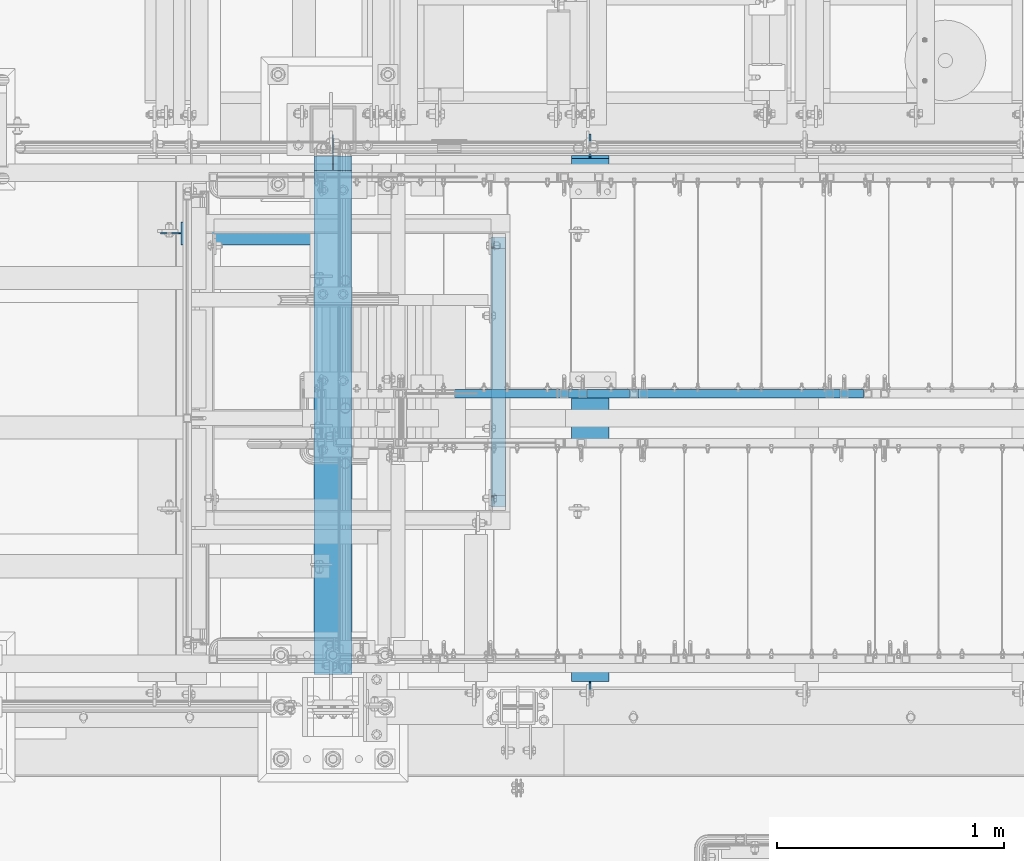
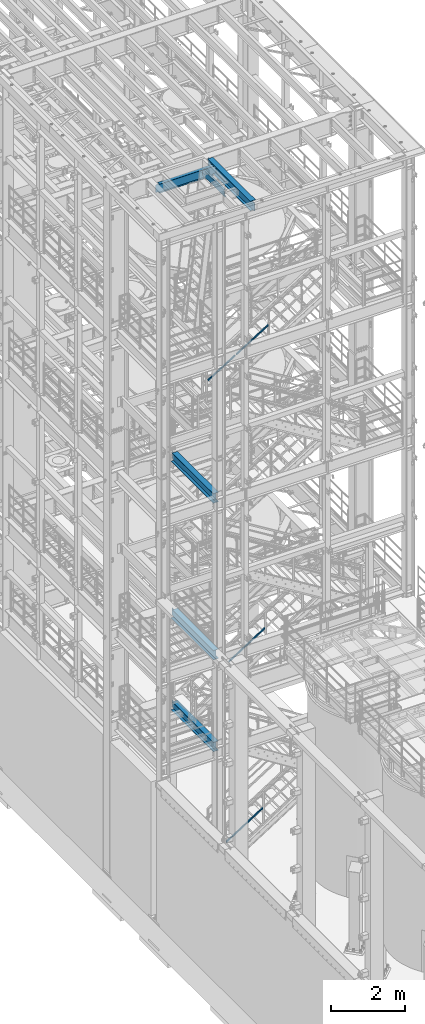
# One storey, part 966 of 1876: 6 beams, 4 members, 9 elements without a shape of their own.
"""IFC2X3 building model written with IfcOpenShell, lengths in millimetres."""

from ifc_helpers import new_model, si_unit, frame, origin_with_axes, place, context, subcontext, project, spatial, faceted_brep, material, type_object, element, aggregate, save


model = new_model("IFC2X3")

# Units and contexts
model_context = context("Model", 3, precision=1e-05, world=origin_with_axes())
body_context = subcontext(model_context, "Body", "Model", "MODEL_VIEW")
ifc_project = project(units=[si_unit("LENGTHUNIT", "METRE", prefix="MILLI"), si_unit("AREAUNIT", "SQUARE_METRE"), si_unit("VOLUMEUNIT", "CUBIC_METRE"), si_unit("MASSUNIT", "GRAM", prefix="KILO"), si_unit("TIMEUNIT", "SECOND"), si_unit("PLANEANGLEUNIT", "RADIAN"), si_unit("SOLIDANGLEUNIT", "STERADIAN"), si_unit("THERMODYNAMICTEMPERATUREUNIT", "DEGREE_CELSIUS"), si_unit("LUMINOUSINTENSITYUNIT", "LUMEN")], contexts=[model_context])

# Site, building, storey
site_placement = place(None, origin_with_axes())
site = spatial("IfcSite", under=ifc_project, at=site_placement, CompositionType="ELEMENT")
building_placement = place(site_placement, origin_with_axes())
building = spatial("IfcBuilding", under=site, at=building_placement, Name="Undefined", CompositionType="ELEMENT")
storey_placement = place(building_placement, origin_with_axes())
storey = spatial("IfcBuildingStorey", under=building, at=storey_placement, Name="Undefined", CompositionType="ELEMENT", Elevation=0.0)

# Assembly, beam
assembly_1_placement = place(storey_placement, origin_with_axes())
assembly_1 = element("IfcElementAssembly", 1, at=assembly_1_placement, inside=storey, Name="BEAM", AssemblyPlace="NOTDEFINED", PredefinedType="RIGID_FRAME")
ifc_material_1 = material(Name="STEEL/A992")
beam_type_1 = type_object("IfcBeamType", Name="W12X16", PredefinedType="NOTDEFINED")
beam_1_placement = place(assembly_1_placement, frame((949.325, -5029.2, 22402.8), z_axis=(0.0, 0.0, 1.0), x_axis=(1.0, 0.0, 0.0)))
beam_1 = element("IfcBeam", 2, at=beam_1_placement, type_object=beam_type_1, material=ifc_material_1, Name="BEAM", ObjectType="W12X16", context=body_context, shape_type="Brep", body=[
    faceted_brep([(1802.60625, -3.17500000000018, -146.049999999999), (1802.60625, -50.8000000000002, -146.049999999999), (1802.60625, -50.8000000000002, -152.400000000001), (1802.60625, 50.8000000000002, -152.400000000001), (1802.60625, 50.8000000000002, -146.049999999999), (1802.60625, 3.17500000000018, -146.049999999999), (1802.60625, 3.17500000000018, -139.699999809265), (1802.60625, -3.17500000000018, -139.699999809265), (1803.57297992259, 3.17500000000018, -134.839920291219), (1803.57297992259, -3.17500000000018, -134.839920291219), (1806.32599382307, 3.17500000000018, -130.719743823065), (1806.32599382307, -3.17500000000018, -130.719743823065), (1810.44617029122, 3.17500000000018, -127.966729922588), (1810.44617029122, -3.17500000000018, -127.966729922588), (1815.30624980927, 3.17500000000018, -127.0), (1815.30624980927, -3.17500000000018, -127.0), (1891.50625, -3.17500000000018, -127.0), (1891.50625, 3.17500000000018, -127.0), (1802.60625, 50.8000000000002, 146.049999999999), (1802.60625, 3.17500000000018, 146.049999999999), (108.74375, 3.17500000000018, 146.049999999999), (108.74375, 50.8000000000002, 146.049999999999), (108.74375, -3.17499999999995, -139.699999809261), (108.74375, 3.17500002570978, -139.699999809261), (108.74375, 3.17500009516311, -146.049999999999), (108.74375, 50.8, -146.049999999999), (108.74375, 50.8, -152.400000000001), (108.74375, -50.8, -152.400000000001), (108.74375, -50.8, -146.049999999999), (108.74375, -3.17499999999995, -146.049999999999), (107.777020077412, -3.17499999999995, -134.839920291215), (107.777020077412, 3.17500002492102, -134.839920291215), (105.024006176934, -3.17499999999995, -130.719743823061), (105.024006176934, 3.17500002425209, -130.719743823061), (100.90382970878, -3.17499999999995, -127.966729922584), (100.90382970878, 3.17500002380461, -127.966729922584), (96.0437501907345, -3.17499999999995, -126.999999999996), (96.0437501907345, 3.17500002364682, -126.999999999996), (19.84375, -3.17499999999995, -126.999999999996), (19.84375, 3.17499999999995, -126.999999999996), (19.8437500000002, -3.17500000000018, 127.0), (19.8437500000002, 3.17500000000018, 127.0), (96.043750190735, -3.17500000000018, 127.0), (96.043750190735, 3.17500000000018, 127.0), (100.90382970878, -3.17500000000018, 127.966729922588), (100.90382970878, 3.17500000000018, 127.966729922588), (105.024006176934, -3.17500000000018, 130.719743823065), (105.024006176934, 3.17500000000018, 130.719743823065), (107.777020077412, -3.17500000000018, 134.839920291219), (107.777020077412, 3.17500000000018, 134.839920291219), (108.74375, -3.17500000000018, 139.699999809265), (108.74375, 3.17500000000018, 139.699999809265), (108.74375, -50.8000000000002, 152.400000000001), (108.74375, 50.8000000000002, 152.400000000001), (108.74375, -3.17500000000018, 146.049999999999), (108.74375, -50.8000000000002, 146.049999999999), (1802.60625, -3.17500000000018, 146.049999999999), (1802.60625, -50.8000000000002, 146.049999999999), (1802.60625, -50.8000000000002, 152.400000000001), (1802.60625, 50.8000000000002, 152.400000000001), (1802.60625, -3.17500000000018, 139.699999809265), (1802.60625, 3.17500000000018, 139.699999809265), (1803.57297992259, -3.17500000000018, 134.839920291219), (1803.57297992259, 3.17500000000018, 134.839920291219), (1806.32599382307, -3.17500000000018, 130.719743823065), (1806.32599382307, 3.17500000000018, 130.719743823065), (1810.44617029122, -3.17500000000018, 127.966729922588), (1810.44617029122, 3.17500000000018, 127.966729922588), (1815.30624980927, -3.17500000000018, 127.0), (1815.30624980927, 3.17500000000018, 127.0), (1891.50625, -3.17500000000018, 127.0), (1891.50625, 3.17500000000018, 127.0)], [[[0, 1, 2, 3, 4, 5, 6, 7]], [[7, 6, 8, 9]], [[9, 8, 10, 11]], [[11, 10, 12, 13]], [[13, 12, 14, 15]], [[16, 15, 14, 17]], [[18, 19, 20, 21]], [[22, 23, 24, 25, 26, 27, 28, 29]], [[30, 31, 23, 22]], [[32, 33, 31, 30]], [[34, 35, 33, 32]], [[36, 37, 35, 34]], [[38, 39, 37, 36]], [[40, 41, 39, 38]], [[42, 43, 41, 40]], [[44, 45, 43, 42]], [[46, 47, 45, 44]], [[48, 49, 47, 46]], [[50, 51, 49, 48]], [[52, 53, 21, 20, 51, 50, 54, 55]], [[56, 57, 55, 54]], [[57, 58, 52, 55]], [[58, 59, 53, 52]], [[59, 18, 21, 53]], [[58, 57, 56, 60, 61, 19, 18, 59]], [[62, 63, 61, 60]], [[64, 65, 63, 62]], [[66, 67, 65, 64]], [[68, 69, 67, 66]], [[70, 71, 69, 68]], [[71, 70, 16, 17]], [[33, 35, 37, 39, 41, 43, 45, 47, 49, 51, 20, 19, 61, 63, 65, 67, 69, 71, 17, 14, 12, 10, 8, 6, 5, 24, 23, 31]], [[5, 4, 25, 24]], [[4, 3, 26, 25]], [[3, 2, 27, 26]], [[2, 1, 28, 27]], [[1, 0, 29, 28]], [[0, 7, 9, 11, 13, 15, 16, 70, 68, 66, 64, 62, 60, 56, 54, 50, 48, 46, 44, 42, 40, 38, 36, 34, 32, 30, 22, 29]]]),
])
aggregate(assembly_1, [beam_1])

# Assembly, member
assembly_2_placement = place(storey_placement, origin_with_axes())
assembly_2 = element("IfcElementAssembly", 3, at=assembly_2_placement, inside=storey, Name="RAIL", AssemblyPlace="NOTDEFINED", PredefinedType="RIGID_FRAME")
ifc_material_2 = material()
member_type = type_object("IfcMemberType", Name="HSS1-1/2X1-1/2X1/8", PredefinedType="NOTDEFINED")
member_1_placement = place(assembly_2_placement, frame((2743.20000001392, -5734.05000114554, 710.652585995032), z_axis=(-0.53569741975471, 0.0, 0.844410015613355), x_axis=(0.844410015326383, 0.0, 0.535697420207059)))
member_1 = element("IfcMember", 4, at=member_1_placement, type_object=member_type, material=ifc_material_2, Name="RAIL", ObjectType="HSS1-1/2X1-1/2X1/8", context=body_context, shape_type="Brep", body=[
    faceted_brep([(1373.21326696754, -19.0499992349996, 19.0499992350346), (1349.04246072927, -19.0499992349996, -19.049999234971), (1349.04246072927, 19.0499992349996, -19.049999234971), (1373.21326696754, 19.0499992349996, 19.0499992350346), (1371.19903306392, -15.8749992829999, 15.8749992830342), (1371.19903306392, 15.8749992829999, 15.8749992830342), (1351.0566946329, 15.8749992829999, -15.8749992829707), (1351.0566946329, -15.8749992829999, -15.8749992829707), (34.6455325374254, 19.0499992349996, 19.049999235012), (34.6455325374254, -19.0499992349996, 19.049999235012), (10.4747262991696, -19.0499992349996, -19.0499992349991), (10.4747262991696, 19.0499992349996, -19.0499992349991), (32.6312986338025, 15.8749992829999, 15.8749992830109), (32.6312986338025, -15.8749992829999, 15.8749992830109), (12.4889602027924, -15.8749992829999, -15.8749992829981), (12.4889602027924, 15.8749992829999, -15.8749992829981)], [[[0, 1, 2, 3], [4, 5, 6, 7]], [[0, 3, 8, 9]], [[2, 1, 10, 11]], [[1, 0, 9, 10]], [[3, 2, 11, 8]], [[10, 9, 8, 11], [12, 13, 14, 15]], [[4, 7, 14, 13]], [[7, 6, 15, 14]], [[6, 5, 12, 15]], [[5, 4, 13, 12]]]),
])
aggregate(assembly_2, [member_1])

assembly_3_placement = place(storey_placement, origin_with_axes())
assembly_3 = element("IfcElementAssembly", 5, at=assembly_3_placement, inside=storey, Name="RAIL", AssemblyPlace="NOTDEFINED", PredefinedType="RIGID_FRAME")
member_2_placement = place(assembly_3_placement, frame((2825.74999894891, -5734.05000114554, 6615.25681662695), z_axis=(-0.536875491934336, 0.0, 0.843661487896813), x_axis=(0.843661487896813, 0.0, 0.536875491934336)))
member_2 = element("IfcMember", 6, at=member_2_placement, type_object=member_type, material=ifc_material_2, Name="RAIL", ObjectType="HSS1-1/2X1-1/2X1/8", context=body_context, shape_type="Brep", body=[
    faceted_brep([(1351.87808442446, -19.0499992349996, 19.0499992351442), (1327.63263086906, -19.0499992349996, -19.0499992348527), (1327.63263086906, 19.0499992349996, -19.0499992348527), (1351.87808442446, 19.0499992349996, 19.0499992351442), (1349.85762991092, -15.8749992829999, 15.8749992831449), (1349.85762991092, 15.8749992829999, 15.8749992831449), (1329.6530853826, 15.8749992829999, -15.8749992828534), (1329.6530853826, -15.8749992829999, -15.8749992828534), (10.4574188235219, 19.0499992349996, -19.0499992349946), (34.7028723789208, 19.0499992349996, 19.0499992350083), (34.7028723789208, -19.0499992349996, 19.0499992350083), (10.4574188235219, -19.0499992349996, -19.0499992349946), (32.6824178653787, 15.8749992829999, 15.8749992830085), (32.6824178653787, -15.8749992829999, 15.8749992830085), (12.4778733370622, -15.8749992829999, -15.8749992829939), (12.4778733370622, 15.8749992829999, -15.8749992829939)], [[[0, 1, 2, 3], [4, 5, 6, 7]], [[3, 2, 8, 9]], [[0, 3, 9, 10]], [[1, 0, 10, 11]], [[2, 1, 11, 8]], [[11, 10, 9, 8], [12, 13, 14, 15]], [[4, 7, 14, 13]], [[7, 6, 15, 14]], [[6, 5, 12, 15]], [[5, 4, 13, 12]]]),
])
aggregate(assembly_3, [member_2])

# Assembly, members
assembly_4_placement = place(storey_placement, origin_with_axes())
assembly_4 = element("IfcElementAssembly", 7, at=assembly_4_placement, inside=storey, Name="RAIL", AssemblyPlace="NOTDEFINED", PredefinedType="RIGID_FRAME")
member_3_placement = place(assembly_4_placement, frame((3048.79374923312, -5734.05000114554, 16638.4068944088), z_axis=(-0.526627379729772, 0.0, 0.850096231563789), x_axis=(0.850096231563789, 0.0, 0.526627379729772)))
member_3 = element("IfcMember", 8, at=member_3_placement, type_object=member_type, material=ifc_material_2, Name="RAIL", ObjectType="HSS1-1/2X1-1/2X1/8", context=body_context, shape_type="Brep", body=[
    faceted_brep([(1200.42409716882, -19.0499992349996, 19.0499992367259), (1176.8214724105, -19.0499992349996, -19.0499992332807), (1176.8214724105, 19.0499992349996, -19.0499992332807), (1200.42409716882, 19.0499992349996, 19.0499992367259), (1198.45721172304, -15.8749992829999, 15.8749992847224), (1198.45721172304, 15.8749992829999, 15.8749992847224), (1178.78835785628, 15.8749992829999, -15.8749992812809), (1178.78835785628, -15.8749992829999, -15.8749992812809), (34.210539160511, 19.0499992349996, 19.0499992350342), (34.210539160511, -19.0499992349996, 19.0499992350342), (10.6079144021951, -19.0499992349996, -19.0499992349669), (10.6079144021951, 19.0499992349996, -19.0499992349669), (32.243653714735, 15.8749992829999, 15.8749992830344), (32.243653714735, -15.8749992829999, 15.8749992830344), (12.574799847971, -15.8749992829999, -15.8749992829671), (12.574799847971, 15.8749992829999, -15.8749992829671)], [[[0, 1, 2, 3], [4, 5, 6, 7]], [[0, 3, 8, 9]], [[2, 1, 10, 11]], [[1, 0, 9, 10]], [[3, 2, 11, 8]], [[10, 9, 8, 11], [12, 13, 14, 15]], [[4, 7, 14, 13]], [[7, 6, 15, 14]], [[6, 5, 12, 15]], [[5, 4, 13, 12]]]),
])
member_4_placement = place(assembly_4_placement, frame((2184.16517293812, -5734.05000114554, 16102.7768508108), z_axis=(-0.526627379729772, 0.0, 0.850096231563789), x_axis=(0.850096231563789, 0.0, 0.526627379729772)))
member_4 = element("IfcMember", 9, at=member_4_placement, type_object=member_type, material=ifc_material_2, Name="RAIL", ObjectType="HSS1-1/2X1-1/2X1/8", context=body_context, shape_type="Brep", body=[
    faceted_brep([(-4.5187969689996, 15.8749992829999, -15.8749992829871), (-4.5187969689996, -15.8749992829999, -15.8749992829871), (984.851287056972, -15.8749992829999, -15.8749992830835), (984.851287056972, 15.8749992829999, -15.8749992830835), (4.51879699284473, -15.8749992829999, 15.8749992829871), (1004.52014092365, -15.8749992829999, 15.8749992828907), (4.51879699284473, 15.8749992829999, 15.8749992829871), (1004.52014092365, 15.8749992829999, 15.8749992828907), (-5.42255639234099, 19.0499992349996, -19.0499992349833), (5.42255641618613, 19.0499992349996, 19.0499992349851), (1006.48702636942, 19.0499992349996, 19.0499992348905), (982.884401611205, 19.0499992349996, -19.0499992350778), (5.42255641618613, -19.0499992349996, 19.0499992349851), (1006.48702636942, -19.0499992349996, 19.0499992348905), (-5.42255639234099, -19.0499992349996, -19.0499992349833), (982.884401611205, -19.0499992349996, -19.0499992350778)], [[[0, 1, 2, 3]], [[1, 4, 5, 2]], [[4, 6, 7, 5]], [[6, 0, 3, 7]], [[8, 9, 10, 11]], [[9, 12, 13, 10]], [[12, 14, 15, 13]], [[14, 8, 11, 15]], [[13, 15, 11, 10], [5, 7, 3, 2]], [[14, 12, 9, 8], [6, 4, 1, 0]]]),
])
aggregate(assembly_4, [member_3, member_4])

# Assembly, beam
assembly_5_placement = place(storey_placement, origin_with_axes())
assembly_5 = element("IfcElementAssembly", 10, at=assembly_5_placement, inside=storey, Name="BEAM", AssemblyPlace="NOTDEFINED", PredefinedType="RIGID_FRAME")
beam_type_2 = type_object("IfcBeamType", Name="C8X18.75", PredefinedType="NOTDEFINED")
beam_2_placement = place(assembly_5_placement, frame((2454.275, -6248.4, 22453.6), z_axis=(0.0, 0.0, 1.0), x_axis=(0.0, 1.0, 0.0)))
beam_2 = element("IfcBeam", 11, at=beam_2_placement, type_object=beam_type_2, material=ifc_material_1, Name="BEAM", ObjectType="C8X18.75", context=body_context, shape_type="Brep", body=[
    faceted_brep([(53.975000190735, 19.0500000000002, 82.5500000000029), (53.975000190735, 31.75, 82.5500000000029), (15.875, 31.75, 82.5500000000065), (15.875, 19.0499999999993, 82.5500000000065), (58.8350797087805, 19.0500000000002, 83.5167299225905), (58.8350797087805, 31.75, 83.5167299225905), (62.9552561769342, 19.0500000000002, 86.269743823068), (62.9552561769342, 31.75, 86.269743823068), (65.7082700774126, 10.11452406229, 90.3899202912216), (65.7082700774126, 31.75, 90.3899202912216), (64.7135857534849, 19.0500000000002, 88.9012699999985), (66.6750000000002, -19.0576219043701, 95.249999809268), (66.6750000000002, 31.75, 95.249999809268), (66.6750000000002, -31.75, 101.599999999999), (66.6750000000002, 31.75, 101.599999999999), (66.6750000000002, -31.75, 97.3645499999984), (15.875, 19.0499999999993, -88.9012699999985), (15.875, -31.75, -97.3645499999984), (1203.325, -31.75, -97.3645499999984), (1203.325, 19.0500000000002, -88.9012699999985), (15.875, -31.75, -101.599999999999), (1203.325, -31.75, -101.599999999999), (15.875, 31.75, -101.599999999999), (1203.325, 31.75, -101.599999999999), (1203.325, 31.75, 82.5500000000029), (1203.325, 19.0500000000002, 82.5500000000029), (1165.22499980927, 31.75, 82.5500000000029), (1165.22499980927, 19.0500000000002, 82.5500000000029), (1160.36492029122, 31.75, 83.5167299225905), (1160.36492029122, 19.0500000000002, 83.5167299225905), (1156.24474382307, 31.75, 86.269743823068), (1156.24474382307, 19.0500000000002, 86.269743823068), (1153.49172992259, 31.75, 90.3899202912216), (1153.49172992259, 10.11452406229, 90.3899202912216), (1154.48641424652, 19.0500000000002, 88.9012699999985), (1152.525, 31.75, 95.249999809268), (1152.525, -19.0576219043701, 95.249999809268), (1152.525, -31.75, 101.599999999999), (1152.525, -31.75, 97.3645499999984), (1152.525, 31.75, 101.599999999999)], [[[0, 1, 2, 3]], [[4, 5, 1, 0]], [[6, 7, 5, 4]], [[8, 9, 7, 6, 10]], [[11, 12, 9, 8]], [[13, 14, 12, 11, 15]], [[16, 17, 18, 19]], [[17, 20, 21, 18]], [[20, 22, 23, 21]], [[19, 18, 21, 23, 24, 25]], [[25, 24, 26, 27]], [[27, 26, 28, 29]], [[29, 28, 30, 31]], [[31, 30, 32, 33, 34]], [[33, 32, 35, 36]], [[37, 38, 36, 35, 39]], [[38, 37, 13, 15]], [[8, 10, 34, 33, 36, 38, 15, 11]], [[4, 0, 3, 16, 19, 25, 27, 29, 31, 34, 10, 6]], [[22, 20, 17, 16, 3, 2]], [[39, 35, 32, 30, 28, 26, 24, 23, 22, 2, 1, 5, 7, 9, 12, 14]], [[37, 39, 14, 13]]]),
])
aggregate(assembly_5, [beam_2])

assembly_6_placement = place(storey_placement, origin_with_axes())
assembly_6 = element("IfcElementAssembly", 12, at=assembly_6_placement, inside=storey, Name="BEAM", AssemblyPlace="NOTDEFINED", PredefinedType="RIGID_FRAME")
beam_type_3 = type_object("IfcBeamType", Name="W12X30", PredefinedType="NOTDEFINED")
beam_3_placement = place(assembly_6_placement, frame((1727.2, -7112.0, 13152.4375), z_axis=(0.0, 0.0, 1.0), x_axis=(0.0, 1.0, 0.0)))
beam_3 = element("IfcBeam", 13, at=beam_3_placement, type_object=beam_type_3, material=ifc_material_1, Name="BEAM", ObjectType="W12X30", context=body_context, shape_type="Brep", body=[
    faceted_brep([(2424.1125, -3.17500000000018, -146.049999999999), (2424.1125, -82.5500000000002, -146.049999999999), (2424.1125, -82.5500000000002, -157.1625), (2424.1125, 82.5500000000002, -157.1625), (2424.1125, 82.5500000000002, -146.049999999999), (2424.1125, 3.17500000000018, -146.049999999999), (2424.1125, 3.17500000000018, -144.462499809264), (2424.1125, -3.17500000000018, -144.462499809264), (2425.07922992259, 3.17500000000018, -139.602420291218), (2425.07922992259, -3.17500000000018, -139.602420291218), (2427.83224382307, 3.17500000000018, -135.482243823064), (2427.83224382307, -3.17500000000018, -135.482243823064), (2431.95242029122, 3.17500000000018, -132.729229922586), (2431.95242029122, -3.17500000000018, -132.729229922586), (2436.81249980927, 3.17500000000018, -131.762499999999), (2436.81249980927, -3.17500000000018, -131.762499999999), (2519.3625, -3.17500000000018, -131.762499999999), (2519.3625, 3.17500000000018, -131.762499999999), (142.875, 3.17499999999995, 146.049999999999), (142.875, 82.55, 146.049999999999), (2360.6125, 82.5500000000002, 146.049999999999), (2360.6125, 3.17500000000018, 146.049999999999), (142.875, -82.55, -157.162499999999), (142.875, -82.55, -146.049999999999), (142.875, -3.17499999999995, -146.049999999999), (142.875, -3.17499999999995, 146.049999999999), (142.875, -82.55, 146.049999999999), (142.875, -82.55, 157.162499999999), (142.875, 82.55, 157.162499999999), (142.875, 3.17499999999995, -146.049999999999), (142.875, 82.55, -146.049999999999), (142.875, 82.55, -157.162499999999), (2360.6125, -3.17500000000018, 146.049999999999), (2360.6125, -82.5500000000002, 146.049999999999), (2360.6125, -82.5500000000002, 157.1625), (2360.6125, 82.5500000000002, 157.1625), (2360.6125, -3.17500000000018, 119.062499809266), (2360.6125, 3.17500000000018, 119.062499809266), (2361.57922992259, -3.17500000000018, 114.20242029122), (2361.57922992259, 3.17500000000018, 114.20242029122), (2364.33224382307, -3.17500000000018, 110.082243823066), (2364.33224382307, 3.17500000000018, 110.082243823066), (2368.45242029122, -3.17500000000018, 107.329229922589), (2368.45242029122, 3.17500000000018, 107.329229922589), (2373.31249980927, -3.17500000000018, 106.362500000001), (2373.31249980927, 3.17500000000018, 106.362500000001), (2519.3625, -3.17500000000018, 106.362500000001), (2519.3625, 3.17500000000018, 106.362500000001)], [[[0, 1, 2, 3, 4, 5, 6, 7]], [[7, 6, 8, 9]], [[9, 8, 10, 11]], [[11, 10, 12, 13]], [[13, 12, 14, 15]], [[16, 15, 14, 17]], [[18, 19, 20, 21]], [[22, 23, 24, 25, 26, 27, 28, 19, 18, 29, 30, 31]], [[26, 25, 32, 33]], [[27, 26, 33, 34]], [[28, 27, 34, 35]], [[19, 28, 35, 20]], [[34, 33, 32, 36, 37, 21, 20, 35]], [[38, 39, 37, 36]], [[40, 41, 39, 38]], [[42, 43, 41, 40]], [[44, 45, 43, 42]], [[46, 47, 45, 44]], [[47, 46, 16, 17]], [[12, 10, 8, 6, 5, 29, 18, 21, 37, 39, 41, 43, 45, 47, 17, 14]], [[30, 29, 5, 4]], [[31, 30, 4, 3]], [[22, 31, 3, 2]], [[23, 22, 2, 1]], [[24, 23, 1, 0]], [[46, 44, 42, 40, 38, 36, 32, 25, 24, 0, 7, 9, 11, 13, 15, 16]]]),
])
aggregate(assembly_6, [beam_3])

assembly_7_placement = place(storey_placement, origin_with_axes())
assembly_7 = element("IfcElementAssembly", 14, at=assembly_7_placement, inside=storey, Name="BEAM", AssemblyPlace="NOTDEFINED", PredefinedType="RIGID_FRAME")
beam_4_placement = place(assembly_7_placement, frame((1727.2, -7112.0, 7996.2375), z_axis=(0.0, 0.0, 1.0), x_axis=(0.0, 1.0, 0.0)))
beam_4 = element("IfcBeam", 15, at=beam_4_placement, type_object=beam_type_3, material=ifc_material_1, Name="BEAM", ObjectType="W12X30", context=body_context, shape_type="Brep", body=[
    faceted_brep([(2421.73125, -3.17500000000018, -146.05), (2421.73125, -82.5500000000002, -146.05), (2421.73125, -82.5500000000002, -157.1625), (2421.73125, 82.5500000000002, -157.1625), (2421.73125, 82.5500000000002, -146.05), (2421.73125, 3.17500000000018, -146.05), (2421.73125, 3.17500000000018, -144.462499809265), (2421.73125, -3.17500000000018, -144.462499809265), (2422.69797992259, 3.17500000000018, -139.602420291219), (2422.69797992259, -3.17500000000018, -139.602420291219), (2425.45099382307, 3.17500000000018, -135.482243823066), (2425.45099382307, -3.17500000000018, -135.482243823066), (2429.57117029122, 3.17500000000018, -132.729229922587), (2429.57117029122, -3.17500000000018, -132.729229922587), (2434.43124980927, 3.17500000000018, -131.7625), (2434.43124980927, -3.17500000000018, -131.7625), (2516.98125, -3.17500000000018, -131.7625), (2516.98125, 3.17500000000018, -131.7625), (142.875, 3.17499999999995, 146.049999999999), (142.875, 82.55, 146.049999999999), (2358.23125, 82.5500000000002, 146.05), (2358.23125, 3.17500000000018, 146.05), (142.875, -82.55, -157.162499999999), (142.875, -82.55, -146.049999999999), (142.875, -3.17499999999995, -146.049999999999), (142.875, -3.17499999999995, 146.049999999999), (142.875, -82.55, 146.049999999999), (142.875, -82.55, 157.162499999999), (142.875, 82.55, 157.162499999999), (142.875, 3.17499999999995, -146.049999999999), (142.875, 82.55, -146.049999999999), (142.875, 82.55, -157.162499999999), (2358.23125, -3.17500000000018, 146.05), (2358.23125, -82.5500000000002, 146.05), (2358.23125, -82.5500000000002, 157.1625), (2358.23125, 82.5500000000002, 157.1625), (2358.23125, -3.17500000000018, 119.062499809265), (2358.23125, 3.17500000000018, 119.062499809265), (2359.19797992259, -3.17500000000018, 114.20242029122), (2359.19797992259, 3.17500000000018, 114.20242029122), (2361.95099382307, -3.17500000000018, 110.082243823066), (2361.95099382307, 3.17500000000018, 110.082243823066), (2366.07117029122, -3.17500000000018, 107.329229922588), (2366.07117029122, 3.17500000000018, 107.329229922588), (2370.93124980927, -3.17500000000018, 106.3625), (2370.93124980927, 3.17500000000018, 106.3625), (2516.98125, -3.17500000000018, 106.3625), (2516.98125, 3.17500000000018, 106.3625)], [[[0, 1, 2, 3, 4, 5, 6, 7]], [[7, 6, 8, 9]], [[9, 8, 10, 11]], [[11, 10, 12, 13]], [[13, 12, 14, 15]], [[16, 15, 14, 17]], [[18, 19, 20, 21]], [[22, 23, 24, 25, 26, 27, 28, 19, 18, 29, 30, 31]], [[26, 25, 32, 33]], [[27, 26, 33, 34]], [[28, 27, 34, 35]], [[19, 28, 35, 20]], [[34, 33, 32, 36, 37, 21, 20, 35]], [[38, 39, 37, 36]], [[40, 41, 39, 38]], [[42, 43, 41, 40]], [[44, 45, 43, 42]], [[46, 47, 45, 44]], [[47, 46, 16, 17]], [[12, 10, 8, 6, 5, 29, 18, 21, 37, 39, 41, 43, 45, 47, 17, 14]], [[30, 29, 5, 4]], [[31, 30, 4, 3]], [[22, 31, 3, 2]], [[23, 22, 2, 1]], [[24, 23, 1, 0]], [[46, 44, 42, 40, 38, 36, 32, 25, 24, 0, 7, 9, 11, 13, 15, 16]]]),
])
aggregate(assembly_7, [beam_4])

assembly_8_placement = place(storey_placement, origin_with_axes())
assembly_8 = element("IfcElementAssembly", 16, at=assembly_8_placement, inside=storey, Name="BEAM", AssemblyPlace="NOTDEFINED", PredefinedType="RIGID_FRAME")
beam_5_placement = place(assembly_8_placement, frame((1727.2, -7112.0, 4973.6375), z_axis=(0.0, 0.0, 1.0), x_axis=(0.0, 1.0, 0.0)))
beam_5 = element("IfcBeam", 17, at=beam_5_placement, type_object=beam_type_3, material=ifc_material_1, Name="BEAM", ObjectType="W12X30", context=body_context, shape_type="Brep", body=[
    faceted_brep([(2421.73125, -3.17500000000018, -146.05), (2421.73125, -82.5500000000002, -146.05), (2421.73125, -82.5500000000002, -157.1625), (2421.73125, 82.5500000000002, -157.1625), (2421.73125, 82.5500000000002, -146.05), (2421.73125, 3.17500000000018, -146.05), (2421.73125, 3.17500000000018, -144.462499809265), (2421.73125, -3.17500000000018, -144.462499809265), (2422.69797992259, 3.17500000000018, -139.602420291219), (2422.69797992259, -3.17500000000018, -139.602420291219), (2425.45099382307, 3.17500000000018, -135.482243823066), (2425.45099382307, -3.17500000000018, -135.482243823066), (2429.57117029122, 3.17500000000018, -132.729229922587), (2429.57117029122, -3.17500000000018, -132.729229922587), (2434.43124980927, 3.17500000000018, -131.7625), (2434.43124980927, -3.17500000000018, -131.7625), (2516.98125, -3.17500000000018, -131.7625), (2516.98125, 3.17500000000018, -131.7625), (142.875, 3.17499999999995, 146.049999999999), (142.875, 82.55, 146.049999999999), (2358.23125, 82.5500000000002, 146.05), (2358.23125, 3.17500000000018, 146.05), (142.875, -82.55, -157.162499999999), (142.875, -82.55, -146.049999999999), (142.875, -3.17499999999995, -146.049999999999), (142.875, -3.17499999999995, 146.049999999999), (142.875, -82.55, 146.049999999999), (142.875, -82.55, 157.162499999999), (142.875, 82.55, 157.162499999999), (142.875, 3.17499999999995, -146.049999999999), (142.875, 82.55, -146.049999999999), (142.875, 82.55, -157.162499999999), (2358.23125, -3.17500000000018, 146.05), (2358.23125, -82.5500000000002, 146.05), (2358.23125, -82.5500000000002, 157.1625), (2358.23125, 82.5500000000002, 157.1625), (2358.23125, -3.17500000000018, 119.062499809265), (2358.23125, 3.17500000000018, 119.062499809265), (2359.19797992259, -3.17500000000018, 114.20242029122), (2359.19797992259, 3.17500000000018, 114.20242029122), (2361.95099382307, -3.17500000000018, 110.082243823066), (2361.95099382307, 3.17500000000018, 110.082243823066), (2366.07117029122, -3.17500000000018, 107.329229922588), (2366.07117029122, 3.17500000000018, 107.329229922588), (2370.93124980927, -3.17500000000018, 106.3625), (2370.93124980927, 3.17500000000018, 106.3625), (2516.98125, -3.17500000000018, 106.3625), (2516.98125, 3.17500000000018, 106.3625)], [[[0, 1, 2, 3, 4, 5, 6, 7]], [[7, 6, 8, 9]], [[9, 8, 10, 11]], [[11, 10, 12, 13]], [[13, 12, 14, 15]], [[16, 15, 14, 17]], [[18, 19, 20, 21]], [[22, 23, 24, 25, 26, 27, 28, 19, 18, 29, 30, 31]], [[26, 25, 32, 33]], [[27, 26, 33, 34]], [[28, 27, 34, 35]], [[19, 28, 35, 20]], [[34, 33, 32, 36, 37, 21, 20, 35]], [[38, 39, 37, 36]], [[40, 41, 39, 38]], [[42, 43, 41, 40]], [[44, 45, 43, 42]], [[46, 47, 45, 44]], [[47, 46, 16, 17]], [[12, 10, 8, 6, 5, 29, 18, 21, 37, 39, 41, 43, 45, 47, 17, 14]], [[30, 29, 5, 4]], [[31, 30, 4, 3]], [[22, 31, 3, 2]], [[23, 22, 2, 1]], [[24, 23, 1, 0]], [[46, 44, 42, 40, 38, 36, 32, 25, 24, 0, 7, 9, 11, 13, 15, 16]]]),
])
aggregate(assembly_8, [beam_5])

assembly_9_placement = place(storey_placement, origin_with_axes())
assembly_9 = element("IfcElementAssembly", 18, at=assembly_9_placement, inside=storey, Name="BEAM", AssemblyPlace="NOTDEFINED", PredefinedType="RIGID_FRAME")
beam_type_4 = type_object("IfcBeamType", Name="W12X35", PredefinedType="NOTDEFINED")
beam_6_placement = place(assembly_9_placement, frame((2857.5, -7112.0, 22396.45), z_axis=(0.0, 0.0, 1.0), x_axis=(0.0, 1.0, 0.0)))
beam_6 = element("IfcBeam", 19, at=beam_6_placement, type_object=beam_type_4, material=ifc_material_1, Name="BEAM", ObjectType="W12X35", context=body_context, shape_type="Brep", body=[
    faceted_brep([(17.4624999999996, -3.96875, -133.350000000002), (17.4624999999996, 3.96875, -133.350000000002), (100.012500190735, 3.96875, -133.350000000002), (100.012500190735, -3.96875, -133.350000000002), (104.872579708781, 3.96875, -134.31672992259), (104.872579708781, -3.96875, -134.31672992259), (108.992756176935, 3.96875, -137.069743823067), (108.992756176935, -3.96875, -137.069743823067), (111.745770077413, 3.96875, -141.189920291221), (111.745770077413, -3.96875, -141.189920291221), (112.712500000001, 3.96875, -146.049999999999), (112.712500000001, -3.96875, -146.049999999999), (112.712500000001, -82.5500000000002, -146.049999999999), (112.712500000001, 82.5500000000002, -146.049999999999), (112.712500000001, 82.5500000000002, -158.75), (112.712500000001, -82.5500000000002, -158.75), (2412.20625, 82.5500000000002, 146.049999999999), (2412.20625, 3.96875, 146.049999999999), (112.712500000001, 3.96875, 146.049999999999), (112.712500000001, 82.5500000000002, 146.05), (100.012500190735, -3.96875, 120.649999999998), (100.012500190735, 3.96875, 120.649999999998), (17.4624999999996, 3.96875, 120.649999999998), (17.4624999999996, -3.96875, 120.649999999998), (104.872579708781, -3.96875, 121.616729922585), (104.872579708781, 3.96875, 121.616729922585), (108.992756176935, -3.96875, 124.369743823063), (108.992756176935, 3.96875, 124.369743823063), (111.745770077413, -3.96875, 128.489920291217), (111.745770077413, 3.96875, 128.489920291217), (112.712500000001, -3.96875, 133.349999809263), (112.712500000001, 3.96875, 133.349999809263), (2412.20625, -82.5500000000002, 158.75), (2412.20625, 82.5500000000002, 158.75), (112.712500000001, 82.5500000000002, 158.75), (112.712500000001, -82.5500000000002, 158.75), (2412.20625, -82.5500000000002, 146.049999999999), (112.712500000001, -82.5500000000002, 146.05), (2412.20625, -3.96875, 146.049999999999), (112.712500000001, -3.96875, 146.049999999999), (2412.20625, -3.96875, 133.34999980927), (2412.20625, 3.96875, 133.34999980927), (2413.17297992259, -3.96875, 128.489920291224), (2413.17297992259, 3.96875, 128.489920291224), (2415.92599382307, -3.96875, 124.36974382307), (2415.92599382307, 3.96875, 124.36974382307), (2420.04617029122, -3.96875, 121.616729922593), (2420.04617029122, 3.96875, 121.616729922593), (2424.90624980927, -3.96875, 120.650000000005), (2424.90624980927, 3.96875, 120.650000000005), (2520.15625, -3.96875, 120.650000000005), (2520.15625, 3.96875, 120.650000000005), (2520.15625, -3.96875, -133.349999999995), (2520.15625, 3.96875, -133.349999999995), (2437.60624980927, -3.96875, -133.349999999995), (2437.60624980927, 3.96875, -133.349999999995), (2432.74617029122, -3.96875, -134.316729922582), (2432.74617029122, 3.96875, -134.316729922582), (2428.62599382307, -3.96875, -137.06974382306), (2428.62599382307, 3.96875, -137.06974382306), (2425.87297992259, -3.96875, -141.189920291214), (2425.87297992259, 3.96875, -141.189920291214), (2424.90625, -3.96875, -146.049999999999), (2424.90625, 3.96875, -146.049999999999), (2424.90625, -82.5500000000002, -146.049999999999), (2424.90625, -82.5500000000002, -158.75), (2424.90625, 82.5500000000002, -158.75), (2424.90625, 82.5500000000002, -146.049999999999)], [[[0, 1, 2, 3]], [[3, 2, 4, 5]], [[5, 4, 6, 7]], [[7, 6, 8, 9]], [[9, 8, 10, 11]], [[12, 11, 10, 13, 14, 15]], [[16, 17, 18, 19]], [[20, 21, 22, 23]], [[24, 25, 21, 20]], [[26, 27, 25, 24]], [[28, 29, 27, 26]], [[30, 31, 29, 28]], [[32, 33, 34, 35]], [[36, 32, 35, 37]], [[38, 36, 37, 39]], [[35, 34, 19, 18, 31, 30, 39, 37]], [[33, 16, 19, 34]], [[32, 36, 38, 40, 41, 17, 16, 33]], [[42, 43, 41, 40]], [[44, 45, 43, 42]], [[46, 47, 45, 44]], [[48, 49, 47, 46]], [[50, 51, 49, 48]], [[51, 50, 52, 53]], [[52, 54, 55, 53]], [[56, 57, 55, 54]], [[58, 59, 57, 56]], [[60, 61, 59, 58]], [[62, 63, 61, 60]], [[64, 65, 66, 67, 63, 62]], [[65, 64, 12, 15]], [[66, 65, 15, 14]], [[67, 66, 14, 13]], [[63, 67, 13, 10]], [[6, 4, 2, 1, 22, 21, 25, 27, 29, 31, 18, 17, 41, 43, 45, 47, 49, 51, 53, 55, 57, 59, 61, 63, 10, 8]], [[23, 22, 1, 0]], [[62, 60, 58, 56, 54, 52, 50, 48, 46, 44, 42, 40, 38, 39, 30, 28, 26, 24, 20, 23, 0, 3, 5, 7, 9, 11]], [[64, 62, 11, 12]]]),
])
aggregate(assembly_9, [beam_6])

save(model, "model.ifc")
